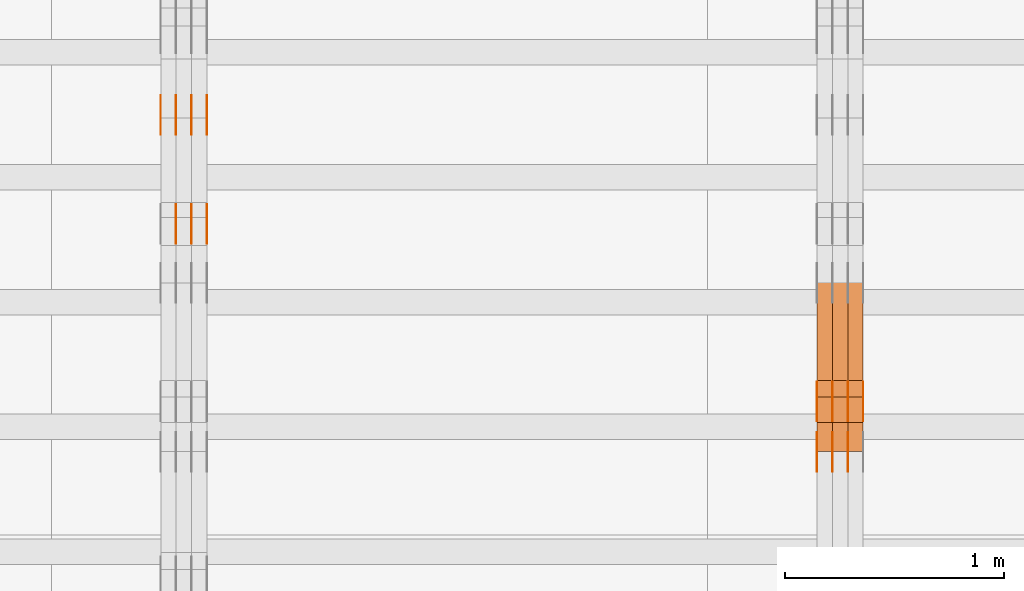
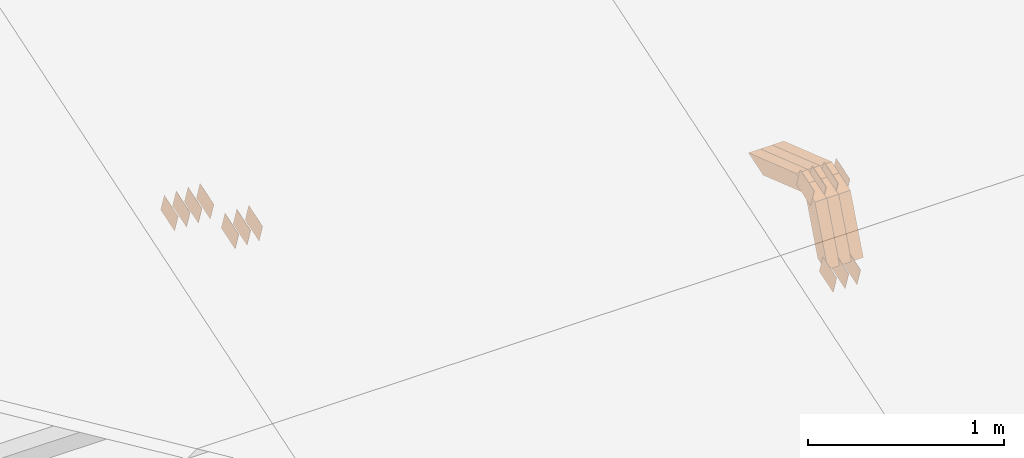
# One storey, part 114 of 385: 28 proxies.
"""IFC2X3 building model written with IfcOpenShell, lengths in millimetres."""

import ifcopenshell
import ifcopenshell.guid

model = None  # the IFC model being written
_history = None  # IfcOwnerHistory: only IFC2X3 demands one
_inside = {}  # id of a spatial element -> (the spatial element, [elements in it])
_under = {}  # id of a project, library or spatial element -> (it, [spatial elements below it])
_declared = {}  # id of a project -> (the project, [libraries it declares])
_typed = {}  # id of a type object -> (the type object, [elements of that type])
_made_of = {}  # id of a material, layer set ... -> (it, [elements and type objects made of it])


def new_model(schema):
    """Start an empty IFC model of exactly this schema.

    Asked for "IFC4X3", IfcOpenShell would pick the latest addendum, in which some entities
    have other attributes; the version numbers below select the first issue.
    IFC2X3 requires an IfcOwnerHistory on every rooted entity: one is made here for all.
    """
    global model, _history
    if schema == "IFC4X3":
        model = ifcopenshell.file(schema_version=(4, 3, 0, 0))
    else:
        model = ifcopenshell.file(schema=schema)
    _inside.clear()
    _under.clear()
    _declared.clear()
    _typed.clear()
    _made_of.clear()
    _history = None
    if model.schema == "IFC2X3":
        org = make("IfcOrganization", Name="unknown")
        user = make(
            "IfcPersonAndOrganization",
            ThePerson=make("IfcPerson", FamilyName="unknown"),
            TheOrganization=org,
        )
        app = make(
            "IfcApplication",
            ApplicationDeveloper=org,
            Version="unknown",
            ApplicationFullName="unknown",
            ApplicationIdentifier="unknown",
        )
        _history = make(
            "IfcOwnerHistory",
            OwningUser=user,
            OwningApplication=app,
            ChangeAction="ADDED",
            CreationDate=0,
        )
    return model


def make(cls, **values):
    """One entity of the class cls with the attributes given. An attribute that is None is left unset."""
    return model.create_entity(
        cls, **{name: value for name, value in values.items() if value is not None}
    )


def entity(cls, *values):
    """Any entity or typed value of the class cls, its attributes in the order of the schema. None: left unset."""
    e = model.create_entity(cls)
    for i, value in enumerate(values):
        if value is not None:
            e[i] = value
    return e


def rooted(cls, **values):
    """An entity with a GlobalId (a new one), such as an element, a storey or a relation."""
    return make(cls, GlobalId=ifcopenshell.guid.new(), OwnerHistory=_history, **values)


def si_unit(unit_type, name, prefix=None):
    """IfcSIUnit, for example si_unit("LENGTHUNIT", "METRE", prefix="MILLI")."""
    return make("IfcSIUnit", UnitType=unit_type, Prefix=prefix, Name=name)


def converted_unit(unit_type, name, factor, base, dimensions=None, offset=None):
    """IfcConversionBasedUnit, such as the inch: factor (a typed value) times the base unit."""
    return make(
        "IfcConversionBasedUnit"
        if offset is None
        else "IfcConversionBasedUnitWithOffset",
        ConversionOffset=offset,
        Dimensions=None
        if dimensions is None
        else entity("IfcDimensionalExponents", *dimensions),
        UnitType=unit_type,
        Name=name,
        ConversionFactor=make(
            "IfcMeasureWithUnit", ValueComponent=factor, UnitComponent=base
        ),
    )


def derived_unit(unit_type, elements):
    """IfcDerivedUnit: a product of units, each with its exponent."""
    return make(
        "IfcDerivedUnit",
        Elements=[
            make("IfcDerivedUnitElement", Unit=unit, Exponent=power)
            for unit, power in elements
        ],
        UnitType=unit_type,
    )


def assignment(units):
    """IfcUnitAssignment: the units of a project."""
    return None if units is None else make("IfcUnitAssignment", Units=units)


def point(xyz):
    """IfcCartesianPoint."""
    return None if xyz is None else make("IfcCartesianPoint", Coordinates=xyz)


def direction(xyz):
    """IfcDirection."""
    return None if xyz is None else make("IfcDirection", DirectionRatios=xyz)


def frame(location, z_axis=None, x_axis=None):
    """IfcAxis2Placement3D, a coordinate frame: its origin and axes. An axis left out is left unset."""
    return make(
        "IfcAxis2Placement3D",
        Location=point(location),
        Axis=direction(z_axis),
        RefDirection=direction(x_axis),
    )


def origin():
    """The frame at (0, 0, 0) with its axes left unset."""
    return frame((0.0, 0.0, 0.0))


def place(relative_to, where):
    """IfcLocalPlacement: puts the frame where relative to a parent placement (None: the world)."""
    return make(
        "IfcLocalPlacement", PlacementRelTo=relative_to, RelativePlacement=where
    )


def context(
    kind, dimensions, precision=None, world=None, true_north=None, identifier=None
):
    """IfcGeometricRepresentationContext, for example the 3D "Model" context."""
    return make(
        "IfcGeometricRepresentationContext",
        ContextIdentifier=identifier,
        ContextType=kind,
        CoordinateSpaceDimension=dimensions,
        Precision=precision,
        WorldCoordinateSystem=world,
        TrueNorth=true_north,
    )


def subcontext(parent, identifier, kind, view, scale=None):
    """IfcGeometricRepresentationSubContext, for example "Body" below "Model"."""
    return make(
        "IfcGeometricRepresentationSubContext",
        ContextIdentifier=identifier,
        ContextType=kind,
        ParentContext=parent,
        TargetScale=scale,
        TargetView=view,
    )


def project(units=None, contexts=None):
    """IfcProject with its units and contexts."""
    return rooted(
        "IfcProject",
        Name="project",
        RepresentationContexts=contexts,
        UnitsInContext=assignment(units),
    )


def spatial(cls, under=None, at=None, **own):
    """A site, building, storey or space (cls), placed at a placement, below another one or the project."""
    s = rooted(cls, ObjectPlacement=at, **own)
    if under is not None:
        _under.setdefault(under.id(), (under, []))[1].append(s)
    return s


def polyline(points):
    """IfcPolyline through the points."""
    return make("IfcPolyline", Points=[point(p) for p in points])


def outline(outer, holes=None, kind="AREA"):
    """IfcArbitraryClosedProfileDef: a profile drawn as a closed curve; with holes, ...WithVoids."""
    if holes is None:
        return make("IfcArbitraryClosedProfileDef", ProfileType=kind, OuterCurve=outer)
    return make(
        "IfcArbitraryProfileDefWithVoids",
        ProfileType=kind,
        OuterCurve=outer,
        InnerCurves=holes,
    )


def extrude(swept, where, along, depth):
    """IfcExtrudedAreaSolid: the profile swept, set in the frame where, extruded along a direction by depth."""
    return make(
        "IfcExtrudedAreaSolid",
        SweptArea=swept,
        Position=where,
        ExtrudedDirection=direction(along),
        Depth=depth,
    )


def shape(context_of_items, identifier, shape_type, items):
    """IfcShapeRepresentation: the items that make up one representation, for example the "Body"."""
    return make(
        "IfcShapeRepresentation",
        ContextOfItems=context_of_items,
        RepresentationIdentifier=identifier,
        RepresentationType=shape_type,
        Items=items,
    )


def source(mapping_origin, context_of_items, identifier, shape_type, items):
    """IfcRepresentationMap: a shape defined once, which mapped items show again and again."""
    return make(
        "IfcRepresentationMap",
        MappingOrigin=mapping_origin,
        MappedRepresentation=shape(context_of_items, identifier, shape_type, items),
    )


def transform(
    local_origin,
    x_axis=None,
    y_axis=None,
    z_axis=None,
    scale=None,
    scale2=None,
    scale3=None,
    uniform=True,
):
    """IfcCartesianTransformationOperator3D, or its non-uniform kind. x_axis, y_axis, z_axis: its Axis1, 2, 3."""
    if uniform:
        return make(
            "IfcCartesianTransformationOperator3D",
            Axis1=direction(x_axis),
            Axis2=direction(y_axis),
            LocalOrigin=point(local_origin),
            Scale=scale,
            Axis3=direction(z_axis),
        )
    return make(
        "IfcCartesianTransformationOperator3DnonUniform",
        Axis1=direction(x_axis),
        Axis2=direction(y_axis),
        LocalOrigin=point(local_origin),
        Scale=scale,
        Axis3=direction(z_axis),
        Scale2=scale2,
        Scale3=scale3,
    )


def mapped(mapping_source, mapping_target):
    """IfcMappedItem: shows the shape of a source again, moved by a transform."""
    return make(
        "IfcMappedItem", MappingSource=mapping_source, MappingTarget=mapping_target
    )


def material(Name=None, Category=None):
    """IfcMaterial."""
    return make("IfcMaterial", Name=Name, Category=Category)


def made_of(thing, what):
    """Note that an element or type object is made of a material, layer set ...; save() writes the relation."""
    if what is not None:
        _made_of.setdefault(what.id(), (what, []))[1].append(thing)
    return thing


def type_object(cls, material=None, **own):
    """A type object (cls), such as IfcWallType, which elements share."""
    return made_of(rooted(cls, **own), material)


def type_shapes(of_type, sources):
    """Give a type object the sources (RepresentationMaps) that its elements show as mapped items."""
    of_type.RepresentationMaps = sources


def element(
    cls,
    number,
    at=None,
    inside=None,
    cuts=None,
    type_object=None,
    material=None,
    context=None,
    identifier="Body",
    shape_type=None,
    held_by="IfcProductDefinitionShape",
    body=None,
    shapes=None,
    **own,
):
    """One element of the class cls, such as IfcWall. Its Tag is "e" and its number.

    at: its placement. inside: the storey or other place that contains it. cuts: it is an
    opening in that element (IfcRelVoidsElement). A single representation is given by context,
    identifier, shape_type and body (its items); several are given by shapes. held_by: the class
    of the entity that holds the representations. save() writes the other relations.
    """
    e = rooted(cls, Tag="e%d" % number, ObjectPlacement=at, **own)
    if body is not None:
        shapes = [shape(context, identifier, shape_type, body)]
    if shapes is not None:
        e.Representation = make(held_by, Representations=shapes)
    if inside is not None:
        _inside.setdefault(inside.id(), (inside, []))[1].append(e)
    if cuts is not None:
        rooted(
            "IfcRelVoidsElement", RelatingBuildingElement=cuts, RelatedOpeningElement=e
        )
    if type_object is not None:
        _typed.setdefault(type_object.id(), (type_object, []))[1].append(e)
    return made_of(e, material)


def aggregate(whole, parts):
    """IfcRelAggregates: a whole, such as a stair, and the parts it consists of."""
    return rooted("IfcRelAggregates", RelatingObject=whole, RelatedObjects=parts)


def save(model, path):
    """Write the relations noted so far, then the file.

    IfcRelAggregates (storeys below a building ...), IfcRelContainedInSpatialStructure (elements
    in a storey), IfcRelDefinesByType, IfcRelAssociatesMaterial and IfcRelDeclares: one each for
    every whole, place, type object, material and project.
    """
    for whole, parts in _under.values():
        aggregate(whole, parts)
    for where, things in _inside.values():
        rooted(
            "IfcRelContainedInSpatialStructure",
            RelatedElements=things,
            RelatingStructure=where,
        )
    for kind, things in _typed.values():
        rooted("IfcRelDefinesByType", RelatedObjects=things, RelatingType=kind)
    for what, things in _made_of.values():
        rooted("IfcRelAssociatesMaterial", RelatedObjects=things, RelatingMaterial=what)
    for by, libraries in _declared.values():
        rooted("IfcRelDeclares", RelatingContext=by, RelatedDefinitions=libraries)
    model.write(path)


model = new_model("IFC2X3")

# Units and contexts
model_context = context("Model", 3, precision=0.01, world=origin(), true_north=direction((6.12303176911189e-17, 1.0)))
body_context = subcontext(model_context, "Body", "Model", "MODEL_VIEW")
ifc_project = project(units=[si_unit("LENGTHUNIT", "METRE", prefix="MILLI"), si_unit("AREAUNIT", "SQUARE_METRE"), si_unit("VOLUMEUNIT", "CUBIC_METRE"), converted_unit("PLANEANGLEUNIT", "DEGREE", entity("IfcRatioMeasure", 0.0174532925199433), si_unit("PLANEANGLEUNIT", "RADIAN"), dimensions=[0, 0, 0, 0, 0, 0, 0]), si_unit("MASSUNIT", "GRAM", prefix="KILO"), derived_unit("MASSDENSITYUNIT", [(si_unit("MASSUNIT", "GRAM", prefix="KILO"), 1), (si_unit("LENGTHUNIT", "METRE"), -3)]), si_unit("TIMEUNIT", "SECOND"), si_unit("FREQUENCYUNIT", "HERTZ"), si_unit("THERMODYNAMICTEMPERATUREUNIT", "DEGREE_CELSIUS"), derived_unit("THERMALTRANSMITTANCEUNIT", [(si_unit("MASSUNIT", "GRAM", prefix="KILO"), 1), (si_unit("THERMODYNAMICTEMPERATUREUNIT", "KELVIN"), -1), (si_unit("TIMEUNIT", "SECOND"), -3)]), derived_unit("VOLUMETRICFLOWRATEUNIT", [(si_unit("LENGTHUNIT", "METRE"), 3), (si_unit("TIMEUNIT", "SECOND"), -1)]), si_unit("ELECTRICCURRENTUNIT", "AMPERE"), si_unit("ELECTRICVOLTAGEUNIT", "VOLT"), si_unit("POWERUNIT", "WATT"), si_unit("FORCEUNIT", "NEWTON", prefix="KILO"), si_unit("ILLUMINANCEUNIT", "LUX"), si_unit("LUMINOUSFLUXUNIT", "LUMEN"), si_unit("LUMINOUSINTENSITYUNIT", "CANDELA"), derived_unit("USERDEFINED", [(si_unit("MASSUNIT", "GRAM", prefix="KILO"), -1), (si_unit("LENGTHUNIT", "METRE"), -2), (si_unit("TIMEUNIT", "SECOND"), 3), (si_unit("LUMINOUSFLUXUNIT", "LUMEN"), 1)]), derived_unit("LINEARVELOCITYUNIT", [(si_unit("LENGTHUNIT", "METRE"), 1), (si_unit("TIMEUNIT", "SECOND"), -1)]), si_unit("PRESSUREUNIT", "PASCAL"), derived_unit("USERDEFINED", [(si_unit("LENGTHUNIT", "METRE"), -2), (si_unit("MASSUNIT", "GRAM", prefix="KILO"), 1), (si_unit("TIMEUNIT", "SECOND"), -2)])], contexts=[model_context])

# Site, building, storey
site_placement = place(None, origin())
site = spatial("IfcSite", under=ifc_project, at=site_placement, CompositionType="ELEMENT")
building_placement = place(site_placement, origin())
building = spatial("IfcBuilding", under=site, at=building_placement, CompositionType="ELEMENT")
storey_placement = place(building_placement, origin())
storey = spatial("IfcBuildingStorey", under=building, at=storey_placement, Name="Default", CompositionType="ELEMENT", Elevation=0.0)

# Proxies
ifc_material_1 = material(Name="IfcSurfaceStyle #270081")
building_element_proxy_type_1 = type_object("IfcBuildingElementProxyType", PredefinedType="NOTDEFINED", material=ifc_material_1)
shared_shape_1 = source(origin(), body_context, "Body", "SweptSolid", [
    extrude(outline(polyline([(-74.9998801438441, -60.0000306612856), (74.9998747047876, -60.0000306612856), (74.9998707133936, 60.0000306612856), (-74.9998652743371, 60.0000306612856), (-74.9998801438441, -60.0000306612856)])), frame((75.0000206139493, 60.0000306612856, 0.0), z_axis=(0.0, 0.0, 1.0), x_axis=(-1.0, 0.0, 0.0)), (0.0, 0.0, 1.0), 1.3),
])
type_shapes(building_element_proxy_type_1, [shared_shape_1])
proxy_1_placement = place(building_placement, frame((21315.0, 5987.08381858242, 1121.42116774683), z_axis=(-1.0, 0.0, 0.0), x_axis=(0.0, 0.951056516295124, 0.309016994375039)))
element("IfcBuildingElementProxy", 1, at=proxy_1_placement, inside=storey, type_object=building_element_proxy_type_1, material=ifc_material_1, context=body_context, shape_type="MappedRepresentation", body=[
    mapped(shared_shape_1, transform((0.0, 0.0, 0.0), scale=1.0)),
])
ifc_material_2 = material(Name="IfcSurfaceStyle #270024")
building_element_proxy_type_2 = type_object("IfcBuildingElementProxyType", PredefinedType="NOTDEFINED", material=ifc_material_2)
shared_shape_2 = source(origin(), body_context, "Body", "SweptSolid", [
    extrude(outline(polyline([(-74.9998801438441, -60.0000306612856), (74.9998747047876, -60.0000306612856), (74.9998707133936, 60.0000306612856), (-74.9998652743371, 60.0000306612856), (-74.9998801438441, -60.0000306612856)])), frame((75.0000206139493, 60.0000306612856, 0.0), z_axis=(0.0, 0.0, 1.0), x_axis=(-1.0, 0.0, 0.0)), (0.0, 0.0, 1.0), 1.3),
])
type_shapes(building_element_proxy_type_2, [shared_shape_2])
proxy_2_placement = place(building_placement, frame((21316.3, 5987.08381858242, 1121.42116774683), z_axis=(-1.0, 0.0, 0.0), x_axis=(0.0, 0.951056516295124, 0.309016994375039)))
element("IfcBuildingElementProxy", 2, at=proxy_2_placement, inside=storey, type_object=building_element_proxy_type_2, material=ifc_material_2, context=body_context, shape_type="MappedRepresentation", body=[
    mapped(shared_shape_2, transform((0.0, 0.0, 0.0), scale=1.0)),
])
ifc_material_3 = material(Name="IfcSurfaceStyle #269967")
building_element_proxy_type_3 = type_object("IfcBuildingElementProxyType", PredefinedType="NOTDEFINED", material=ifc_material_3)
shared_shape_3 = source(origin(), body_context, "Body", "SweptSolid", [
    extrude(outline(polyline([(-74.9998801438441, -60.0000306612856), (74.9998747047876, -60.0000306612856), (74.9998707133936, 60.0000306612856), (-74.9998652743371, 60.0000306612856), (-74.9998801438441, -60.0000306612856)])), frame((75.0000206139493, 60.0000306612856, 0.0), z_axis=(0.0, 0.0, 1.0), x_axis=(-1.0, 0.0, 0.0)), (0.0, 0.0, 1.0), 1.29999999999999),
])
type_shapes(building_element_proxy_type_3, [shared_shape_3])
proxy_3_placement = place(building_placement, frame((21245.0, 5987.08381858242, 1121.42116774683), z_axis=(-1.0, 0.0, 0.0), x_axis=(0.0, 0.951056516295124, 0.309016994375039)))
element("IfcBuildingElementProxy", 3, at=proxy_3_placement, inside=storey, type_object=building_element_proxy_type_3, material=ifc_material_3, context=body_context, shape_type="MappedRepresentation", body=[
    mapped(shared_shape_3, transform((0.0, 0.0, 0.0), scale=1.0)),
])
ifc_material_4 = material(Name="IfcSurfaceStyle #269910")
building_element_proxy_type_4 = type_object("IfcBuildingElementProxyType", PredefinedType="NOTDEFINED", material=ifc_material_4)
shared_shape_4 = source(origin(), body_context, "Body", "SweptSolid", [
    extrude(outline(polyline([(-74.9998801438441, -60.0000306612856), (74.9998747047876, -60.0000306612856), (74.9998707133936, 60.0000306612856), (-74.9998652743371, 60.0000306612856), (-74.9998801438441, -60.0000306612856)])), frame((75.0000206139493, 60.0000306612856, 0.0), z_axis=(0.0, 0.0, 1.0), x_axis=(-1.0, 0.0, 0.0)), (0.0, 0.0, 1.0), 1.29999999999999),
])
type_shapes(building_element_proxy_type_4, [shared_shape_4])
proxy_4_placement = place(building_placement, frame((21246.3, 5987.08381858242, 1121.42116774683), z_axis=(-1.0, 0.0, 0.0), x_axis=(0.0, 0.951056516295124, 0.309016994375039)))
element("IfcBuildingElementProxy", 4, at=proxy_4_placement, inside=storey, type_object=building_element_proxy_type_4, material=ifc_material_4, context=body_context, shape_type="MappedRepresentation", body=[
    mapped(shared_shape_4, transform((0.0, 0.0, 0.0), scale=1.0)),
])
ifc_material_5 = material(Name="IfcSurfaceStyle #269853")
building_element_proxy_type_5 = type_object("IfcBuildingElementProxyType", PredefinedType="NOTDEFINED", material=ifc_material_5)
shared_shape_5 = source(origin(), body_context, "Body", "SweptSolid", [
    extrude(outline(polyline([(-74.9998801438441, -60.0000306612856), (74.9998747047876, -60.0000306612856), (74.9998707133936, 60.0000306612856), (-74.9998652743371, 60.0000306612856), (-74.9998801438441, -60.0000306612856)])), frame((75.0000206139493, 60.0000306612856, 0.0), z_axis=(0.0, 0.0, 1.0), x_axis=(-1.0, 0.0, 0.0)), (0.0, 0.0, 1.0), 1.29999999999999),
])
type_shapes(building_element_proxy_type_5, [shared_shape_5])
proxy_5_placement = place(building_placement, frame((21175.0, 5987.08381858242, 1121.42116774683), z_axis=(-1.0, 0.0, 0.0), x_axis=(0.0, 0.951056516295124, 0.309016994375039)))
element("IfcBuildingElementProxy", 5, at=proxy_5_placement, inside=storey, type_object=building_element_proxy_type_5, material=ifc_material_5, context=body_context, shape_type="MappedRepresentation", body=[
    mapped(shared_shape_5, transform((0.0, 0.0, 0.0), scale=1.0)),
])
ifc_material_6 = material(Name="IfcSurfaceStyle #265692")
building_element_proxy_type_6 = type_object("IfcBuildingElementProxyType", PredefinedType="NOTDEFINED", material=ifc_material_6)
shared_shape_6 = source(origin(), body_context, "Body", "SweptSolid", [
    extrude(outline(polyline([(-74.9998754286253, -60.0000016373506), (74.999860559109, -60.0000016373506), (74.9998754286235, 60.0000016373506), (-74.9998605591072, 60.0000016373506), (-74.9998754286253, -60.0000016373506)])), frame((75.0001009411744, 60.0000279841752, 0.0), z_axis=(0.0, 0.0, 1.0), x_axis=(-1.0, 0.0, 0.0)), (0.0, 0.0, 1.0), 1.3),
])
type_shapes(building_element_proxy_type_6, [shared_shape_6])
proxy_6_placement = place(building_placement, frame((21386.3, 6218.29662915452, 1523.23574463408), z_axis=(-1.0, 0.0, 0.0), x_axis=(0.0, 0.951056516295154, 0.309016994374948)))
element("IfcBuildingElementProxy", 6, at=proxy_6_placement, inside=storey, type_object=building_element_proxy_type_6, material=ifc_material_6, context=body_context, shape_type="MappedRepresentation", body=[
    mapped(shared_shape_6, transform((0.0, 0.0, 0.0), scale=1.0)),
])
ifc_material_7 = material(Name="IfcSurfaceStyle #265635")
building_element_proxy_type_7 = type_object("IfcBuildingElementProxyType", PredefinedType="NOTDEFINED", material=ifc_material_7)
shared_shape_7 = source(origin(), body_context, "Body", "SweptSolid", [
    extrude(outline(polyline([(-74.9998754286253, -60.0000016373506), (74.999860559109, -60.0000016373506), (74.9998754286235, 60.0000016373506), (-74.9998605591072, 60.0000016373506), (-74.9998754286253, -60.0000016373506)])), frame((75.0001009411744, 60.0000279841752, 0.0), z_axis=(0.0, 0.0, 1.0), x_axis=(-1.0, 0.0, 0.0)), (0.0, 0.0, 1.0), 1.3),
])
type_shapes(building_element_proxy_type_7, [shared_shape_7])
proxy_7_placement = place(building_placement, frame((21315.0, 6218.29662915452, 1523.23574463408), z_axis=(-1.0, 0.0, 0.0), x_axis=(0.0, 0.951056516295154, 0.309016994374948)))
element("IfcBuildingElementProxy", 7, at=proxy_7_placement, inside=storey, type_object=building_element_proxy_type_7, material=ifc_material_7, context=body_context, shape_type="MappedRepresentation", body=[
    mapped(shared_shape_7, transform((0.0, 0.0, 0.0), scale=1.0)),
])
ifc_material_8 = material(Name="IfcSurfaceStyle #265578")
building_element_proxy_type_8 = type_object("IfcBuildingElementProxyType", PredefinedType="NOTDEFINED", material=ifc_material_8)
shared_shape_8 = source(origin(), body_context, "Body", "SweptSolid", [
    extrude(outline(polyline([(-74.9998754286253, -60.0000016373506), (74.999860559109, -60.0000016373506), (74.9998754286235, 60.0000016373506), (-74.9998605591072, 60.0000016373506), (-74.9998754286253, -60.0000016373506)])), frame((75.0001009411744, 60.0000279841752, 0.0), z_axis=(0.0, 0.0, 1.0), x_axis=(-1.0, 0.0, 0.0)), (0.0, 0.0, 1.0), 1.3),
])
type_shapes(building_element_proxy_type_8, [shared_shape_8])
proxy_8_placement = place(building_placement, frame((21316.3, 6218.29662915452, 1523.23574463408), z_axis=(-1.0, 0.0, 0.0), x_axis=(0.0, 0.951056516295154, 0.309016994374948)))
element("IfcBuildingElementProxy", 8, at=proxy_8_placement, inside=storey, type_object=building_element_proxy_type_8, material=ifc_material_8, context=body_context, shape_type="MappedRepresentation", body=[
    mapped(shared_shape_8, transform((0.0, 0.0, 0.0), scale=1.0)),
])
ifc_material_9 = material(Name="IfcSurfaceStyle #265521")
building_element_proxy_type_9 = type_object("IfcBuildingElementProxyType", PredefinedType="NOTDEFINED", material=ifc_material_9)
shared_shape_9 = source(origin(), body_context, "Body", "SweptSolid", [
    extrude(outline(polyline([(-74.9998754286253, -60.0000016373506), (74.999860559109, -60.0000016373506), (74.9998754286235, 60.0000016373506), (-74.9998605591072, 60.0000016373506), (-74.9998754286253, -60.0000016373506)])), frame((75.0001009411744, 60.0000279841752, 0.0), z_axis=(0.0, 0.0, 1.0), x_axis=(-1.0, 0.0, 0.0)), (0.0, 0.0, 1.0), 1.29999999999999),
])
type_shapes(building_element_proxy_type_9, [shared_shape_9])
proxy_9_placement = place(building_placement, frame((21245.0, 6218.29662915452, 1523.23574463408), z_axis=(-1.0, 0.0, 0.0), x_axis=(0.0, 0.951056516295154, 0.309016994374948)))
element("IfcBuildingElementProxy", 9, at=proxy_9_placement, inside=storey, type_object=building_element_proxy_type_9, material=ifc_material_9, context=body_context, shape_type="MappedRepresentation", body=[
    mapped(shared_shape_9, transform((0.0, 0.0, 0.0), scale=1.0)),
])
ifc_material_10 = material(Name="IfcSurfaceStyle #265464")
building_element_proxy_type_10 = type_object("IfcBuildingElementProxyType", PredefinedType="NOTDEFINED", material=ifc_material_10)
shared_shape_10 = source(origin(), body_context, "Body", "SweptSolid", [
    extrude(outline(polyline([(-74.9998754286253, -60.0000016373506), (74.999860559109, -60.0000016373506), (74.9998754286235, 60.0000016373506), (-74.9998605591072, 60.0000016373506), (-74.9998754286253, -60.0000016373506)])), frame((75.0001009411744, 60.0000279841752, 0.0), z_axis=(0.0, 0.0, 1.0), x_axis=(-1.0, 0.0, 0.0)), (0.0, 0.0, 1.0), 1.29999999999999),
])
type_shapes(building_element_proxy_type_10, [shared_shape_10])
proxy_10_placement = place(building_placement, frame((21246.3, 6218.29662915452, 1523.23574463408), z_axis=(-1.0, 0.0, 0.0), x_axis=(0.0, 0.951056516295154, 0.309016994374948)))
element("IfcBuildingElementProxy", 10, at=proxy_10_placement, inside=storey, type_object=building_element_proxy_type_10, material=ifc_material_10, context=body_context, shape_type="MappedRepresentation", body=[
    mapped(shared_shape_10, transform((0.0, 0.0, 0.0), scale=1.0)),
])
ifc_material_11 = material(Name="IfcSurfaceStyle #265407")
building_element_proxy_type_11 = type_object("IfcBuildingElementProxyType", PredefinedType="NOTDEFINED", material=ifc_material_11)
shared_shape_11 = source(origin(), body_context, "Body", "SweptSolid", [
    extrude(outline(polyline([(-74.9998754286253, -60.0000016373506), (74.999860559109, -60.0000016373506), (74.9998754286235, 60.0000016373506), (-74.9998605591072, 60.0000016373506), (-74.9998754286253, -60.0000016373506)])), frame((75.0001009411744, 60.0000279841752, 0.0), z_axis=(0.0, 0.0, 1.0), x_axis=(-1.0, 0.0, 0.0)), (0.0, 0.0, 1.0), 1.29999999999999),
])
type_shapes(building_element_proxy_type_11, [shared_shape_11])
proxy_11_placement = place(building_placement, frame((21175.0, 6218.29662915452, 1523.23574463408), z_axis=(-1.0, 0.0, 0.0), x_axis=(0.0, 0.951056516295154, 0.309016994374948)))
element("IfcBuildingElementProxy", 11, at=proxy_11_placement, inside=storey, type_object=building_element_proxy_type_11, material=ifc_material_11, context=body_context, shape_type="MappedRepresentation", body=[
    mapped(shared_shape_11, transform((0.0, 0.0, 0.0), scale=1.0)),
])
ifc_material_12 = material(Name="IfcSurfaceStyle #252696")
building_element_proxy_type_12 = type_object("IfcBuildingElementProxyType", Name="T1-W19 252694", PredefinedType="NOTDEFINED", material=ifc_material_12)
shared_shape_12 = source(origin(), body_context, "Body", "SweptSolid", [
    extrude(outline(polyline([(-234.986199656822, -47.5000587840676), (221.224626701627, -47.5000587840676), (219.29748584664, -9.04449542012076e-05), (156.014457007826, 47.5001040065446), (-361.550369899272, 47.5001040065447), (-234.986199656822, -47.5000587840676)])), frame((221.224626701627, 47.5001108598228, 0.0), z_axis=(0.0, 0.0, 1.0), x_axis=(-1.0, 0.0, 0.0)), (0.0, 0.0, 1.0), 70.0),
])
type_shapes(building_element_proxy_type_12, [shared_shape_12])
proxy_12_placement = place(building_placement, frame((21385.0, 6342.4042570111, 1541.63383639481), z_axis=(-1.0, 0.0, 0.0), x_axis=(0.0, 0.9461301511345, -0.323786561046329)))
element("IfcBuildingElementProxy", 12, at=proxy_12_placement, inside=storey, type_object=building_element_proxy_type_12, material=ifc_material_12, Name="T1-W19", context=body_context, shape_type="MappedRepresentation", body=[
    mapped(shared_shape_12, transform((0.0, 0.0, 0.0), scale=1.0)),
])
ifc_material_13 = material(Name="IfcSurfaceStyle #252630")
building_element_proxy_type_13 = type_object("IfcBuildingElementProxyType", Name="T1-W19 252628", PredefinedType="NOTDEFINED", material=ifc_material_13)
shared_shape_13 = source(origin(), body_context, "Body", "SweptSolid", [
    extrude(outline(polyline([(-234.986199656822, -47.5000587840676), (221.224626701627, -47.5000587840676), (219.29748584664, -9.04449542012076e-05), (156.014457007826, 47.5001040065446), (-361.550369899272, 47.5001040065447), (-234.986199656822, -47.5000587840676)])), frame((221.224626701627, 47.5001108598228, 0.0), z_axis=(0.0, 0.0, 1.0), x_axis=(-1.0, 0.0, 0.0)), (0.0, 0.0, 1.0), 70.0),
])
type_shapes(building_element_proxy_type_13, [shared_shape_13])
proxy_13_placement = place(building_placement, frame((21315.0, 6342.4042570111, 1541.63383639481), z_axis=(-1.0, 0.0, 0.0), x_axis=(0.0, 0.9461301511345, -0.323786561046329)))
element("IfcBuildingElementProxy", 13, at=proxy_13_placement, inside=storey, type_object=building_element_proxy_type_13, material=ifc_material_13, Name="T1-W19", context=body_context, shape_type="MappedRepresentation", body=[
    mapped(shared_shape_13, transform((0.0, 0.0, 0.0), scale=1.0)),
])
ifc_material_14 = material(Name="IfcSurfaceStyle #252564")
building_element_proxy_type_14 = type_object("IfcBuildingElementProxyType", Name="T1-W19 252562", PredefinedType="NOTDEFINED", material=ifc_material_14)
shared_shape_14 = source(origin(), body_context, "Body", "SweptSolid", [
    extrude(outline(polyline([(-234.986199656822, -47.5000587840676), (221.224626701627, -47.5000587840676), (219.29748584664, -9.04449542012076e-05), (156.014457007826, 47.5001040065446), (-361.550369899272, 47.5001040065447), (-234.986199656822, -47.5000587840676)])), frame((221.224626701627, 47.5001108598228, 0.0), z_axis=(0.0, 0.0, 1.0), x_axis=(-1.0, 0.0, 0.0)), (0.0, 0.0, 1.0), 70.0),
])
type_shapes(building_element_proxy_type_14, [shared_shape_14])
proxy_14_placement = place(building_placement, frame((21245.0, 6342.4042570111, 1541.63383639481), z_axis=(-1.0, 0.0, 0.0), x_axis=(0.0, 0.9461301511345, -0.323786561046329)))
element("IfcBuildingElementProxy", 14, at=proxy_14_placement, inside=storey, type_object=building_element_proxy_type_14, material=ifc_material_14, Name="T1-W19", context=body_context, shape_type="MappedRepresentation", body=[
    mapped(shared_shape_14, transform((0.0, 0.0, 0.0), scale=1.0)),
])
ifc_material_15 = material(Name="IfcSurfaceStyle #252300")
building_element_proxy_type_15 = type_object("IfcBuildingElementProxyType", Name="T1-W46 252298", PredefinedType="NOTDEFINED", material=ifc_material_15)
shared_shape_15 = source(origin(), body_context, "Body", "SweptSolid", [
    extrude(outline(polyline([(-272.224583017384, -47.5002947748381), (128.798007350946, -47.5002947748382), (167.560249082673, 0.000339032424879266), (170.567132940603, 47.500741369691), (-194.700806356838, 47.4995091475604), (-272.224583017384, -47.5002947748381)])), frame((170.567293182179, 47.5001659655231, 0.0), z_axis=(0.0, 0.0, 1.0), x_axis=(-1.0, 3.37347464168628e-06, 0.0)), (0.0, 0.0, 1.0), 70.0),
])
type_shapes(building_element_proxy_type_15, [shared_shape_15])
proxy_15_placement = place(building_placement, frame((21385.0, 6080.046875, 1117.66674804688), z_axis=(-1.0, 0.0, 0.0), x_axis=(0.0, 0.361885618189232, 0.93222250527854)))
element("IfcBuildingElementProxy", 15, at=proxy_15_placement, inside=storey, type_object=building_element_proxy_type_15, material=ifc_material_15, Name="T1-W46", context=body_context, shape_type="MappedRepresentation", body=[
    mapped(shared_shape_15, transform((0.0, 0.0, 0.0), scale=1.0)),
])
ifc_material_16 = material(Name="IfcSurfaceStyle #252234")
building_element_proxy_type_16 = type_object("IfcBuildingElementProxyType", Name="T1-W46 252232", PredefinedType="NOTDEFINED", material=ifc_material_16)
shared_shape_16 = source(origin(), body_context, "Body", "SweptSolid", [
    extrude(outline(polyline([(-272.224583017384, -47.5002947748381), (128.798007350946, -47.5002947748382), (167.560249082673, 0.000339032424879266), (170.567132940603, 47.500741369691), (-194.700806356838, 47.4995091475604), (-272.224583017384, -47.5002947748381)])), frame((170.567293182179, 47.5001659655231, 0.0), z_axis=(0.0, 0.0, 1.0), x_axis=(-1.0, 3.37347464168628e-06, 0.0)), (0.0, 0.0, 1.0), 70.0),
])
type_shapes(building_element_proxy_type_16, [shared_shape_16])
proxy_16_placement = place(building_placement, frame((21315.0, 6080.046875, 1117.66674804688), z_axis=(-1.0, 0.0, 0.0), x_axis=(0.0, 0.361885618189232, 0.93222250527854)))
element("IfcBuildingElementProxy", 16, at=proxy_16_placement, inside=storey, type_object=building_element_proxy_type_16, material=ifc_material_16, Name="T1-W46", context=body_context, shape_type="MappedRepresentation", body=[
    mapped(shared_shape_16, transform((0.0, 0.0, 0.0), scale=1.0)),
])
ifc_material_17 = material(Name="IfcSurfaceStyle #252168")
building_element_proxy_type_17 = type_object("IfcBuildingElementProxyType", Name="T1-W46 252166", PredefinedType="NOTDEFINED", material=ifc_material_17)
shared_shape_17 = source(origin(), body_context, "Body", "SweptSolid", [
    extrude(outline(polyline([(-272.224583017384, -47.5002947748381), (128.798007350946, -47.5002947748382), (167.560249082673, 0.000339032424879266), (170.567132940603, 47.500741369691), (-194.700806356838, 47.4995091475604), (-272.224583017384, -47.5002947748381)])), frame((170.567293182179, 47.5001659655231, 0.0), z_axis=(0.0, 0.0, 1.0), x_axis=(-1.0, 3.37347464168628e-06, 0.0)), (0.0, 0.0, 1.0), 70.0),
])
type_shapes(building_element_proxy_type_17, [shared_shape_17])
proxy_17_placement = place(building_placement, frame((21245.0, 6080.046875, 1117.66674804688), z_axis=(-1.0, 0.0, 0.0), x_axis=(0.0, 0.361885618189232, 0.93222250527854)))
element("IfcBuildingElementProxy", 17, at=proxy_17_placement, inside=storey, type_object=building_element_proxy_type_17, material=ifc_material_17, Name="T1-W46", context=body_context, shape_type="MappedRepresentation", body=[
    mapped(shared_shape_17, transform((0.0, 0.0, 0.0), scale=1.0)),
])
ifc_material_18 = material(Name="IfcSurfaceStyle #242204")
building_element_proxy_type_18 = type_object("IfcBuildingElementProxyType", PredefinedType="NOTDEFINED", material=ifc_material_18)
shared_shape_18 = source(origin(), body_context, "Body", "SweptSolid", [
    extrude(outline(polyline([(-74.9998565677169, -60.0000596852269), (74.9998794200137, -60.0000596852269), (74.9998565677151, 60.0000596852269), (-74.9998794200119, 60.0000596852269), (-74.9998565677169, -60.0000596852269)])), frame((74.9998794200137, 60.0000596852269, 0.0), z_axis=(0.0, 0.0, 1.0), x_axis=(-1.0, 0.0, 0.0)), (0.0, 0.0, 1.0), 1.3),
])
type_shapes(building_element_proxy_type_18, [shared_shape_18])
proxy_18_placement = place(building_placement, frame((18386.3, 7527.6269081625, 1621.97418552253), z_axis=(-1.0, 0.0, 0.0), x_axis=(0.0, 0.951056516295124, 0.309016994375039)))
element("IfcBuildingElementProxy", 18, at=proxy_18_placement, inside=storey, type_object=building_element_proxy_type_18, material=ifc_material_18, context=body_context, shape_type="MappedRepresentation", body=[
    mapped(shared_shape_18, transform((0.0, 0.0, 0.0), scale=1.0)),
])
ifc_material_19 = material(Name="IfcSurfaceStyle #242147")
building_element_proxy_type_19 = type_object("IfcBuildingElementProxyType", PredefinedType="NOTDEFINED", material=ifc_material_19)
shared_shape_19 = source(origin(), body_context, "Body", "SweptSolid", [
    extrude(outline(polyline([(-74.9998565677169, -60.0000596852269), (74.9998794200137, -60.0000596852269), (74.9998565677151, 60.0000596852269), (-74.9998794200119, 60.0000596852269), (-74.9998565677169, -60.0000596852269)])), frame((74.9998794200137, 60.0000596852269, 0.0), z_axis=(0.0, 0.0, 1.0), x_axis=(-1.0, 0.0, 0.0)), (0.0, 0.0, 1.0), 1.3),
])
type_shapes(building_element_proxy_type_19, [shared_shape_19])
proxy_19_placement = place(building_placement, frame((18315.0, 7527.6269081625, 1621.97418552253), z_axis=(-1.0, 0.0, 0.0), x_axis=(0.0, 0.951056516295124, 0.309016994375039)))
element("IfcBuildingElementProxy", 19, at=proxy_19_placement, inside=storey, type_object=building_element_proxy_type_19, material=ifc_material_19, context=body_context, shape_type="MappedRepresentation", body=[
    mapped(shared_shape_19, transform((0.0, 0.0, 0.0), scale=1.0)),
])
ifc_material_20 = material(Name="IfcSurfaceStyle #242090")
building_element_proxy_type_20 = type_object("IfcBuildingElementProxyType", PredefinedType="NOTDEFINED", material=ifc_material_20)
shared_shape_20 = source(origin(), body_context, "Body", "SweptSolid", [
    extrude(outline(polyline([(-74.9998565677169, -60.0000596852269), (74.9998794200137, -60.0000596852269), (74.9998565677151, 60.0000596852269), (-74.9998794200119, 60.0000596852269), (-74.9998565677169, -60.0000596852269)])), frame((74.9998794200137, 60.0000596852269, 0.0), z_axis=(0.0, 0.0, 1.0), x_axis=(-1.0, 0.0, 0.0)), (0.0, 0.0, 1.0), 1.3),
])
type_shapes(building_element_proxy_type_20, [shared_shape_20])
proxy_20_placement = place(building_placement, frame((18316.3, 7527.6269081625, 1621.97418552253), z_axis=(-1.0, 0.0, 0.0), x_axis=(0.0, 0.951056516295124, 0.309016994375039)))
element("IfcBuildingElementProxy", 20, at=proxy_20_placement, inside=storey, type_object=building_element_proxy_type_20, material=ifc_material_20, context=body_context, shape_type="MappedRepresentation", body=[
    mapped(shared_shape_20, transform((0.0, 0.0, 0.0), scale=1.0)),
])
ifc_material_21 = material(Name="IfcSurfaceStyle #242033")
building_element_proxy_type_21 = type_object("IfcBuildingElementProxyType", PredefinedType="NOTDEFINED", material=ifc_material_21)
shared_shape_21 = source(origin(), body_context, "Body", "SweptSolid", [
    extrude(outline(polyline([(-74.9998565677169, -60.0000596852269), (74.9998794200137, -60.0000596852269), (74.9998565677151, 60.0000596852269), (-74.9998794200119, 60.0000596852269), (-74.9998565677169, -60.0000596852269)])), frame((74.9998794200137, 60.0000596852269, 0.0), z_axis=(0.0, 0.0, 1.0), x_axis=(-1.0, 0.0, 0.0)), (0.0, 0.0, 1.0), 1.29999999999999),
])
type_shapes(building_element_proxy_type_21, [shared_shape_21])
proxy_21_placement = place(building_placement, frame((18245.0, 7527.6269081625, 1621.97418552253), z_axis=(-1.0, 0.0, 0.0), x_axis=(0.0, 0.951056516295124, 0.309016994375039)))
element("IfcBuildingElementProxy", 21, at=proxy_21_placement, inside=storey, type_object=building_element_proxy_type_21, material=ifc_material_21, context=body_context, shape_type="MappedRepresentation", body=[
    mapped(shared_shape_21, transform((0.0, 0.0, 0.0), scale=1.0)),
])
ifc_material_22 = material(Name="IfcSurfaceStyle #241976")
building_element_proxy_type_22 = type_object("IfcBuildingElementProxyType", PredefinedType="NOTDEFINED", material=ifc_material_22)
shared_shape_22 = source(origin(), body_context, "Body", "SweptSolid", [
    extrude(outline(polyline([(-74.9998565677169, -60.0000596852269), (74.9998794200137, -60.0000596852269), (74.9998565677151, 60.0000596852269), (-74.9998794200119, 60.0000596852269), (-74.9998565677169, -60.0000596852269)])), frame((74.9998794200137, 60.0000596852269, 0.0), z_axis=(0.0, 0.0, 1.0), x_axis=(-1.0, 0.0, 0.0)), (0.0, 0.0, 1.0), 1.29999999999999),
])
type_shapes(building_element_proxy_type_22, [shared_shape_22])
proxy_22_placement = place(building_placement, frame((18246.3, 7527.6269081625, 1621.97418552253), z_axis=(-1.0, 0.0, 0.0), x_axis=(0.0, 0.951056516295124, 0.309016994375039)))
element("IfcBuildingElementProxy", 22, at=proxy_22_placement, inside=storey, type_object=building_element_proxy_type_22, material=ifc_material_22, context=body_context, shape_type="MappedRepresentation", body=[
    mapped(shared_shape_22, transform((0.0, 0.0, 0.0), scale=1.0)),
])
ifc_material_23 = material(Name="IfcSurfaceStyle #241919")
building_element_proxy_type_23 = type_object("IfcBuildingElementProxyType", PredefinedType="NOTDEFINED", material=ifc_material_23)
shared_shape_23 = source(origin(), body_context, "Body", "SweptSolid", [
    extrude(outline(polyline([(-74.9998565677169, -60.0000596852269), (74.9998794200137, -60.0000596852269), (74.9998565677151, 60.0000596852269), (-74.9998794200119, 60.0000596852269), (-74.9998565677169, -60.0000596852269)])), frame((74.9998794200137, 60.0000596852269, 0.0), z_axis=(0.0, 0.0, 1.0), x_axis=(-1.0, 0.0, 0.0)), (0.0, 0.0, 1.0), 1.29999999999999),
])
type_shapes(building_element_proxy_type_23, [shared_shape_23])
proxy_23_placement = place(building_placement, frame((18175.0, 7527.6269081625, 1621.97418552253), z_axis=(-1.0, 0.0, 0.0), x_axis=(0.0, 0.951056516295124, 0.309016994375039)))
element("IfcBuildingElementProxy", 23, at=proxy_23_placement, inside=storey, type_object=building_element_proxy_type_23, material=ifc_material_23, context=body_context, shape_type="MappedRepresentation", body=[
    mapped(shared_shape_23, transform((0.0, 0.0, 0.0), scale=1.0)),
])
ifc_material_24 = material(Name="IfcSurfaceStyle #231944")
building_element_proxy_type_24 = type_object("IfcBuildingElementProxyType", PredefinedType="NOTDEFINED", material=ifc_material_24)
shared_shape_24 = source(origin(), body_context, "Body", "SweptSolid", [
    extrude(outline(polyline([(-74.9998565677233, -60.0000596852342), (74.9998794200074, -60.0000596852342), (74.9998565677233, 60.0000596852342), (-74.9998794200074, 60.0000596852342), (-74.9998565677233, -60.0000596852342)])), frame((74.9998794200073, 60.0000596852342, 0.0), z_axis=(0.0, 0.0, 1.0), x_axis=(-1.0, 0.0, 0.0)), (0.0, 0.0, 1.0), 1.3),
])
type_shapes(building_element_proxy_type_24, [shared_shape_24])
proxy_24_placement = place(building_placement, frame((18386.3, 7029.15620503751, 1786.70025974129), z_axis=(-1.0, 0.0, 0.0), x_axis=(0.0, 0.951056516295154, 0.309016994374948)))
element("IfcBuildingElementProxy", 24, at=proxy_24_placement, inside=storey, type_object=building_element_proxy_type_24, material=ifc_material_24, context=body_context, shape_type="MappedRepresentation", body=[
    mapped(shared_shape_24, transform((0.0, 0.0, 0.0), scale=1.0)),
])
ifc_material_25 = material(Name="IfcSurfaceStyle #231887")
building_element_proxy_type_25 = type_object("IfcBuildingElementProxyType", PredefinedType="NOTDEFINED", material=ifc_material_25)
shared_shape_25 = source(origin(), body_context, "Body", "SweptSolid", [
    extrude(outline(polyline([(-74.9998565677233, -60.0000596852342), (74.9998794200074, -60.0000596852342), (74.9998565677233, 60.0000596852342), (-74.9998794200074, 60.0000596852342), (-74.9998565677233, -60.0000596852342)])), frame((74.9998794200073, 60.0000596852342, 0.0), z_axis=(0.0, 0.0, 1.0), x_axis=(-1.0, 0.0, 0.0)), (0.0, 0.0, 1.0), 1.3),
])
type_shapes(building_element_proxy_type_25, [shared_shape_25])
proxy_25_placement = place(building_placement, frame((18315.0, 7029.15620503751, 1786.70025974129), z_axis=(-1.0, 0.0, 0.0), x_axis=(0.0, 0.951056516295154, 0.309016994374948)))
element("IfcBuildingElementProxy", 25, at=proxy_25_placement, inside=storey, type_object=building_element_proxy_type_25, material=ifc_material_25, context=body_context, shape_type="MappedRepresentation", body=[
    mapped(shared_shape_25, transform((0.0, 0.0, 0.0), scale=1.0)),
])
ifc_material_26 = material(Name="IfcSurfaceStyle #231830")
building_element_proxy_type_26 = type_object("IfcBuildingElementProxyType", PredefinedType="NOTDEFINED", material=ifc_material_26)
shared_shape_26 = source(origin(), body_context, "Body", "SweptSolid", [
    extrude(outline(polyline([(-74.9998565677233, -60.0000596852342), (74.9998794200074, -60.0000596852342), (74.9998565677233, 60.0000596852342), (-74.9998794200074, 60.0000596852342), (-74.9998565677233, -60.0000596852342)])), frame((74.9998794200073, 60.0000596852342, 0.0), z_axis=(0.0, 0.0, 1.0), x_axis=(-1.0, 0.0, 0.0)), (0.0, 0.0, 1.0), 1.3),
])
type_shapes(building_element_proxy_type_26, [shared_shape_26])
proxy_26_placement = place(building_placement, frame((18316.3, 7029.15620503751, 1786.70025974129), z_axis=(-1.0, 0.0, 0.0), x_axis=(0.0, 0.951056516295154, 0.309016994374948)))
element("IfcBuildingElementProxy", 26, at=proxy_26_placement, inside=storey, type_object=building_element_proxy_type_26, material=ifc_material_26, context=body_context, shape_type="MappedRepresentation", body=[
    mapped(shared_shape_26, transform((0.0, 0.0, 0.0), scale=1.0)),
])
ifc_material_27 = material(Name="IfcSurfaceStyle #231773")
building_element_proxy_type_27 = type_object("IfcBuildingElementProxyType", PredefinedType="NOTDEFINED", material=ifc_material_27)
shared_shape_27 = source(origin(), body_context, "Body", "SweptSolid", [
    extrude(outline(polyline([(-74.9998565677233, -60.0000596852342), (74.9998794200074, -60.0000596852342), (74.9998565677233, 60.0000596852342), (-74.9998794200074, 60.0000596852342), (-74.9998565677233, -60.0000596852342)])), frame((74.9998794200073, 60.0000596852342, 0.0), z_axis=(0.0, 0.0, 1.0), x_axis=(-1.0, 0.0, 0.0)), (0.0, 0.0, 1.0), 1.29999999999999),
])
type_shapes(building_element_proxy_type_27, [shared_shape_27])
proxy_27_placement = place(building_placement, frame((18245.0, 7029.15620503751, 1786.70025974129), z_axis=(-1.0, 0.0, 0.0), x_axis=(0.0, 0.951056516295154, 0.309016994374948)))
element("IfcBuildingElementProxy", 27, at=proxy_27_placement, inside=storey, type_object=building_element_proxy_type_27, material=ifc_material_27, context=body_context, shape_type="MappedRepresentation", body=[
    mapped(shared_shape_27, transform((0.0, 0.0, 0.0), scale=1.0)),
])
ifc_material_28 = material(Name="IfcSurfaceStyle #231716")
building_element_proxy_type_28 = type_object("IfcBuildingElementProxyType", PredefinedType="NOTDEFINED", material=ifc_material_28)
shared_shape_28 = source(origin(), body_context, "Body", "SweptSolid", [
    extrude(outline(polyline([(-74.9998565677233, -60.0000596852342), (74.9998794200074, -60.0000596852342), (74.9998565677233, 60.0000596852342), (-74.9998794200074, 60.0000596852342), (-74.9998565677233, -60.0000596852342)])), frame((74.9998794200073, 60.0000596852342, 0.0), z_axis=(0.0, 0.0, 1.0), x_axis=(-1.0, 0.0, 0.0)), (0.0, 0.0, 1.0), 1.29999999999999),
])
type_shapes(building_element_proxy_type_28, [shared_shape_28])
proxy_28_placement = place(building_placement, frame((18246.3, 7029.15620503751, 1786.70025974129), z_axis=(-1.0, 0.0, 0.0), x_axis=(0.0, 0.951056516295154, 0.309016994374948)))
element("IfcBuildingElementProxy", 28, at=proxy_28_placement, inside=storey, type_object=building_element_proxy_type_28, material=ifc_material_28, context=body_context, shape_type="MappedRepresentation", body=[
    mapped(shared_shape_28, transform((0.0, 0.0, 0.0), scale=1.0)),
])

save(model, "model.ifc")
